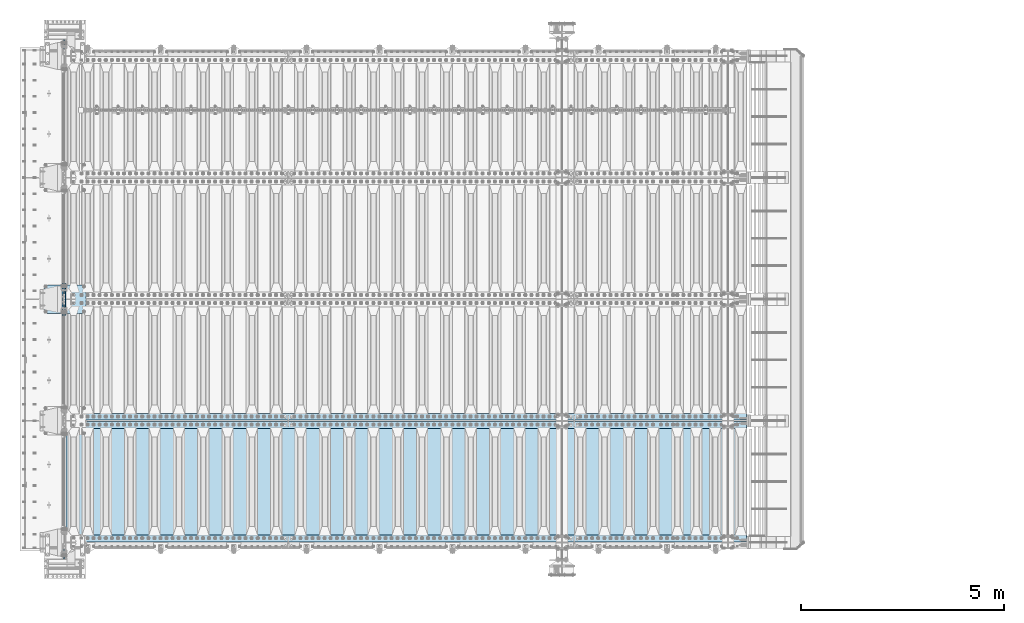
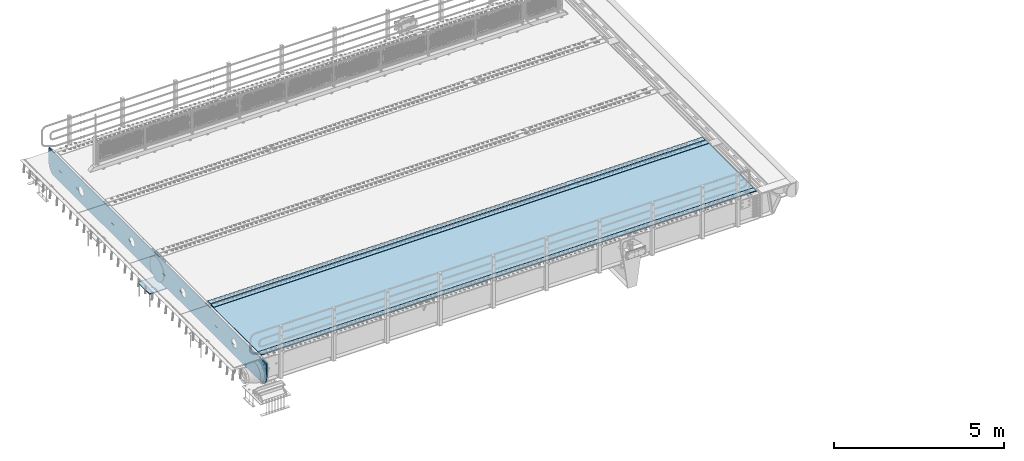
# One storey, part 197 of 257: 8 plates.
"""IFC2X3 building model written with IfcOpenShell, lengths in millimetres."""

from ifc_helpers import new_model, si_unit, frame, origin_with_axes, place, context, subcontext, project, spatial, faceted_brep, material, type_object, element, save


model = new_model("IFC2X3")

# Units and contexts
model_context = context("Model", 3, precision=1e-05, world=origin_with_axes())
body_context = subcontext(model_context, "Body", "Model", "MODEL_VIEW")
ifc_project = project(units=[si_unit("LENGTHUNIT", "METRE", prefix="MILLI"), si_unit("AREAUNIT", "SQUARE_METRE"), si_unit("VOLUMEUNIT", "CUBIC_METRE"), si_unit("MASSUNIT", "GRAM", prefix="KILO"), si_unit("TIMEUNIT", "SECOND"), si_unit("PLANEANGLEUNIT", "RADIAN"), si_unit("SOLIDANGLEUNIT", "STERADIAN"), si_unit("THERMODYNAMICTEMPERATUREUNIT", "DEGREE_CELSIUS"), si_unit("LUMINOUSINTENSITYUNIT", "LUMEN")], contexts=[model_context])

# Site, building, storey
site_placement = place(None, origin_with_axes())
site = spatial("IfcSite", under=ifc_project, at=site_placement, CompositionType="ELEMENT")
building_placement = place(site_placement, origin_with_axes())
building = spatial("IfcBuilding", under=site, at=building_placement, Name="Standard", CompositionType="ELEMENT")
storey_placement = place(building_placement, origin_with_axes())
storey = spatial("IfcBuildingStorey", under=building, at=storey_placement, Name="Undefined", CompositionType="ELEMENT", Elevation=0.0)

# Plates
ifc_material_1 = material(Name="STEEL/S355N")
plate_type_1 = type_object("IfcPlateType", PredefinedType="NOTDEFINED")
plate_1_placement = place(storey_placement, frame((42445.0, 5600.0, -20.0), z_axis=(0.0, 1.0, 0.0), x_axis=(0.0, 0.0, -1.0)))
element("IfcPlate", 1, at=plate_1_placement, inside=storey, type_object=plate_type_1, material=ifc_material_1, context=body_context, shape_type="Brep", body=[
    faceted_brep([(855.0, -15.0, 572.96311467154), (855.0, 15.0, 572.96311467154), (849.182410261294, 15.0, 585.889268817531), (849.182410261294, -15.0, 585.889268817531), (824.193546357474, 15.0, 627.225898692485), (824.193546357474, -15.0, 627.225898692485), (794.404299268454, 15.0, 665.249063296341), (794.404299268454, -15.0, 665.249063296341), (760.249063296334, 15.0, 699.404299268464), (760.249063296334, -15.0, 699.404299268464), (722.22589869248, 15.0, 729.193546357486), (722.22589869248, -15.0, 729.193546357486), (680.889268817528, 15.0, 754.182410261309), (680.889268817528, -15.0, 754.182410261309), (636.841954817037, 15.0, 774.006497074193), (636.841954817037, -15.0, 774.006497074193), (590.726265715048, 15.0, 788.37672697045), (590.726265715048, -15.0, 788.37672697045), (543.214672102156, 15.0, 797.083549639254), (543.214672102156, -15.0, 797.083549639254), (495.0, -15.0, 800.000000000029), (495.0, 15.0, 800.0), (494.999999999412, -15.0, 0.0), (494.999999999412, 15.0, 0.0), (543.214672102129, 15.0, 2.91645036080718), (543.214672102129, -15.0, 2.91645036080718), (590.726265715023, 15.0, 11.6232730296088), (590.726265715023, -15.0, 11.6232730296088), (636.841954817014, 15.0, 25.9935029258631), (636.841954817014, -15.0, 25.9935029258631), (680.889268817507, 15.0, 45.8175897387455), (680.889268817507, -15.0, 45.8175897387455), (722.225898692462, 15.0, 70.8064536425663), (722.225898692462, -15.0, 70.8064536425663), (760.249063296318, 15.0, 100.595700731588), (760.249063296318, -15.0, 100.595700731588), (794.404299268441, 15.0, 134.750936703711), (794.404299268441, -15.0, 134.750936703711), (824.193546357463, 15.0, 172.774101307567), (824.193546357463, -15.0, 172.774101307567), (849.182410261284, 15.0, 214.110731182522), (849.182410261284, -15.0, 214.110731182522), (855.0, -15.0, 227.036885328535), (855.0, 15.0, 227.036885328535), (0.0, -15.0, 0.0), (0.0, 15.0, 0.0), (0.0, 15.0, 800.0), (0.0, -15.0, 800.0)], [[[0, 1, 2, 3]], [[3, 2, 4, 5]], [[5, 4, 6, 7]], [[7, 6, 8, 9]], [[9, 8, 10, 11]], [[11, 10, 12, 13]], [[13, 12, 14, 15]], [[15, 14, 16, 17]], [[17, 16, 18, 19]], [[20, 19, 18, 21]], [[22, 23, 24, 25]], [[25, 24, 26, 27]], [[27, 26, 28, 29]], [[29, 28, 30, 31]], [[31, 30, 32, 33]], [[33, 32, 34, 35]], [[35, 34, 36, 37]], [[37, 36, 38, 39]], [[39, 38, 40, 41]], [[42, 41, 40, 43]], [[42, 43, 1, 0]], [[44, 45, 23, 22]], [[16, 14, 12, 10, 8, 6, 4, 2, 1, 43, 40, 38, 36, 34, 32, 30, 28, 26, 24, 23, 45, 46, 21, 18]], [[44, 47, 46, 45]], [[46, 47, 20, 21]], [[47, 44, 22, 25, 27, 29, 31, 33, 35, 37, 39, 41, 42, 0, 3, 5, 7, 9, 11, 13, 15, 17, 19, 20]]]),
])
plate_type_2 = type_object("IfcPlateType", PredefinedType="NOTDEFINED")
plate_2_placement = place(storey_placement, frame((41926.0, 6350.0, -1043.0), z_axis=(1.0, 0.0, 0.0), x_axis=(0.0, -1.0, 0.0)))
element("IfcPlate", 2, at=plate_2_placement, inside=storey, type_object=plate_type_2, material=ifc_material_1, context=body_context, shape_type="Brep", body=[
    faceted_brep([(0.0, -15.0, 0.0), (3.03448287013453e-05, -15.0, 1025.0), (3.03448287013453e-05, 15.0, 1025.0), (0.0, 15.0, 0.0), (700.0, -15.0, 1025.0), (700.0, 15.0, 1025.0), (700.0, -15.0, -7.27595761418343e-12), (700.0, 15.0, -7.27595761418343e-12)], [[[0, 1, 2, 3]], [[1, 4, 5, 2]], [[4, 6, 7, 5]], [[6, 0, 3, 7]], [[5, 7, 3, 2]], [[6, 4, 1, 0]]]),
])
ifc_material_2 = material(Name="STEEL/S235JR")
plate_type_3 = type_object("IfcPlateType", PredefinedType="NOTDEFINED")
for number, where, z_axis, x_axis in (
    (3, (59257.0, 2815.0, 20.0), (-1.0, 0.0, 0.0), (0.0, 1.0, 0.0)),
    (4, (59257.0, 15.0, 20.0), (-1.0, 0.0, 0.0), (0.0, 1.0, 0.0)),
    (5, (59257.0, 3015.0, 20.0), (-1.0, 0.0, 0.0), (0.0, 1.0, 0.0)),
):
    element("IfcPlate", number, at=place(storey_placement, frame(where, z_axis=z_axis, x_axis=x_axis)), inside=storey, type_object=plate_type_3, material=ifc_material_2, context=body_context, shape_type="Brep", body=[
        faceted_brep([(0.0, -6.0, 0.0), (0.0, -6.0, 16787.0), (0.0, 6.0, 16787.0), (0.0, 6.0, 0.0), (170.0, -6.0, 16787.0), (170.0, 6.0, 16787.0), (170.0, -6.0, 0.0), (170.0, 6.0, 0.0)], [[[0, 1, 2, 3]], [[1, 4, 5, 2]], [[4, 6, 7, 5]], [[6, 0, 3, 7]], [[5, 7, 3, 2]], [[6, 4, 1, 0]]]),
    ])
plate_type_4 = type_object("IfcPlateType", PredefinedType="NOTDEFINED")
plate_3_placement = place(storey_placement, frame((42460.0, 2995.0, 7.0), z_axis=(1.0, 0.0, 0.0), x_axis=(0.0, -1.0, 0.0)))
element("IfcPlate", 6, at=plate_3_placement, inside=storey, type_object=plate_type_4, material=ifc_material_1, context=body_context, shape_type="Brep", body=[
    faceted_brep([(0.0, -7.0, 0.0), (-2.96859070658684e-09, -7.0, 16807.0), (-2.96859070658684e-09, 7.0, 16807.0), (0.0, 7.0, 0.0), (2990.0, -7.0, 16807.0), (2990.0, 7.0, 16807.0), (2990.0, -7.0, 0.0), (2990.0, 7.0, 0.0)], [[[0, 1, 2, 3]], [[1, 4, 5, 2]], [[4, 6, 7, 5]], [[6, 0, 3, 7]], [[5, 7, 3, 2]], [[6, 4, 1, 0]]]),
])
plate_type_5 = type_object("IfcPlateType", PredefinedType="NOTDEFINED")
plate_4_placement = place(storey_placement, frame((42387.5, 6400.0, -114.999999999998), z_axis=(0.0, 0.0, -1.0), x_axis=(0.0, -1.0, 0.0)))
element("IfcPlate", 7, at=plate_4_placement, inside=storey, type_object=plate_type_5, material=ifc_material_1, context=body_context, shape_type="Brep", body=[
    faceted_brep([(-1.13686837721616e-13, -12.5, 400.0), (2.91645036077841, -12.5, 448.214672102129), (2.91645036077841, 12.5, 448.214672102129), (-1.13686837721616e-13, 12.5, 400.0), (11.6232730295792, -12.5, 495.726265715023), (11.6232730295792, 12.5, 495.726265715023), (25.993502925834, -12.5, 541.841954817014), (25.993502925834, 12.5, 541.841954817014), (45.817589738716, -12.5, 585.889268817507), (45.817589738716, 12.5, 585.889268817507), (70.8064536425373, -12.5, 627.225898692462), (70.8064536425373, 12.5, 627.225898692462), (100.595700731559, -12.5, 665.249063296318), (100.595700731559, 12.5, 665.249063296318), (134.750936703682, -12.5, 699.40429926844), (134.750936703682, 12.5, 699.40429926844), (172.774101307538, -12.5, 729.193546357462), (172.774101307538, 12.5, 729.193546357462), (214.110731182492, -12.5, 754.182410261284), (214.110731182492, 12.5, 754.182410261284), (258.158045182986, -12.5, 774.006497074166), (258.158045182986, 12.5, 774.006497074166), (304.273734284977, -12.5, 788.376726970421), (304.273734284977, 12.5, 788.376726970421), (351.78532789787, -12.5, 797.083549639221), (351.78532789787, 12.5, 797.083549639221), (400.0, -12.5, 800.0), (400.0, 12.5, 800.0), (448.214672102129, -12.5, 797.083549639222), (448.214672102129, 12.5, 797.083549639222), (495.726265715023, -12.5, 788.376726970421), (495.726265715023, 12.5, 788.376726970421), (541.841954817014, -12.5, 774.006497074166), (541.841954817014, 12.5, 774.006497074166), (585.889268817507, -12.5, 754.182410261284), (585.889268817507, 12.5, 754.182410261284), (627.225898692462, -12.5, 729.193546357463), (627.225898692462, 12.5, 729.193546357463), (665.249063296318, -12.5, 699.404299268441), (665.249063296318, 12.5, 699.404299268441), (699.40429926844, -12.5, 665.249063296318), (699.40429926844, 12.5, 665.249063296318), (729.193546357463, -12.5, 627.225898692462), (729.193546357463, 12.5, 627.225898692462), (754.182410261284, -12.5, 585.889268817507), (754.182410261284, 12.5, 585.889268817507), (774.006497074166, -12.5, 541.841954817014), (774.006497074166, 12.5, 541.841954817014), (788.376726970421, -12.5, 495.726265715023), (788.376726970421, 12.5, 495.726265715023), (797.083549639222, -12.5, 448.214672102129), (797.083549639222, 12.5, 448.214672102129), (800.0, -12.5, 400.0), (800.0, 12.5, 400.0), (797.083549639222, -12.5, 351.785327897871), (797.083549639222, 12.5, 351.785327897871), (788.376726970421, -12.5, 304.273734284977), (788.376726970421, 12.5, 304.273734284977), (774.006497074166, -12.5, 258.158045182986), (774.006497074166, 12.5, 258.158045182986), (754.182410261284, -12.5, 214.110731182493), (754.182410261284, 12.5, 214.110731182493), (729.193546357463, -12.5, 172.774101307538), (729.193546357463, 12.5, 172.774101307538), (699.40429926844, -12.5, 134.750936703682), (699.40429926844, 12.5, 134.750936703682), (665.249063296318, -12.5, 100.59570073156), (665.249063296318, 12.5, 100.59570073156), (627.225898692462, -12.5, 70.8064536425375), (627.225898692462, 12.5, 70.8064536425375), (585.889268817507, -12.5, 45.817589738716), (585.889268817507, 12.5, 45.817589738716), (541.841954817014, -12.5, 25.9935029258342), (541.841954817014, 12.5, 25.9935029258342), (495.726265715023, -12.5, 11.6232730295793), (495.726265715023, 12.5, 11.6232730295793), (448.214672102129, -12.5, 2.91645036077847), (448.214672102129, 12.5, 2.91645036077847), (400.0, -12.5, -5.6843418860808e-14), (400.0, 12.5, -5.6843418860808e-14), (351.785327897871, -12.5, 2.91645036077836), (351.785327897871, 12.5, 2.91645036077836), (304.273734284977, -12.5, 11.6232730295792), (304.273734284977, 12.5, 11.6232730295792), (258.158045182986, -12.5, 25.993502925834), (258.158045182986, 12.5, 25.993502925834), (214.110731182492, -12.5, 45.817589738716), (214.110731182492, 12.5, 45.817589738716), (172.774101307538, -12.5, 70.8064536425374), (172.774101307538, 12.5, 70.8064536425374), (134.750936703682, -12.5, 100.595700731559), (134.750936703682, 12.5, 100.595700731559), (100.59570073156, -12.5, 134.750936703682), (100.59570073156, 12.5, 134.750936703682), (70.8064536425373, -12.5, 172.774101307538), (70.8064536425373, 12.5, 172.774101307538), (45.817589738716, -12.5, 214.110731182492), (45.817589738716, 12.5, 214.110731182492), (25.993502925834, -12.5, 258.158045182986), (25.993502925834, 12.5, 258.158045182986), (11.6232730295791, -12.5, 304.273734284977), (11.6232730295791, 12.5, 304.273734284977), (2.91645036077836, -12.5, 351.785327897871), (2.91645036077836, 12.5, 351.785327897871)], [[[0, 1, 2, 3]], [[1, 4, 5, 2]], [[4, 6, 7, 5]], [[6, 8, 9, 7]], [[8, 10, 11, 9]], [[10, 12, 13, 11]], [[12, 14, 15, 13]], [[14, 16, 17, 15]], [[16, 18, 19, 17]], [[18, 20, 21, 19]], [[20, 22, 23, 21]], [[22, 24, 25, 23]], [[24, 26, 27, 25]], [[26, 28, 29, 27]], [[28, 30, 31, 29]], [[30, 32, 33, 31]], [[32, 34, 35, 33]], [[34, 36, 37, 35]], [[36, 38, 39, 37]], [[38, 40, 41, 39]], [[40, 42, 43, 41]], [[42, 44, 45, 43]], [[44, 46, 47, 45]], [[46, 48, 49, 47]], [[48, 50, 51, 49]], [[50, 52, 53, 51]], [[52, 54, 55, 53]], [[54, 56, 57, 55]], [[56, 58, 59, 57]], [[58, 60, 61, 59]], [[60, 62, 63, 61]], [[62, 64, 65, 63]], [[64, 66, 67, 65]], [[66, 68, 69, 67]], [[68, 70, 71, 69]], [[70, 72, 73, 71]], [[72, 74, 75, 73]], [[74, 76, 77, 75]], [[76, 78, 79, 77]], [[78, 80, 81, 79]], [[80, 82, 83, 81]], [[82, 84, 85, 83]], [[84, 86, 87, 85]], [[86, 88, 89, 87]], [[88, 90, 91, 89]], [[90, 92, 93, 91]], [[92, 94, 95, 93]], [[94, 96, 97, 95]], [[96, 98, 99, 97]], [[98, 100, 101, 99]], [[100, 102, 103, 101]], [[102, 0, 3, 103]], [[5, 7, 9, 11, 13, 15, 17, 19, 21, 23, 25, 27, 29, 31, 33, 35, 37, 39, 41, 43, 45, 47, 49, 51, 53, 55, 57, 59, 61, 63, 65, 67, 69, 71, 73, 75, 77, 79, 81, 83, 85, 87, 89, 91, 93, 95, 97, 99, 101, 103, 3, 2]], [[102, 100, 98, 96, 94, 92, 90, 88, 86, 84, 82, 80, 78, 76, 74, 72, 70, 68, 66, 64, 62, 60, 58, 56, 54, 52, 50, 48, 46, 44, 42, 40, 38, 36, 34, 32, 30, 28, 26, 24, 22, 20, 18, 16, 14, 12, 10, 8, 6, 4, 1, 0]]]),
])
plate_type_6 = type_object("IfcPlateType", PredefinedType="NOTDEFINED")
plate_5_placement = place(storey_placement, frame((42415.0, -400.0, -36.0000190935184), z_axis=(0.0, 1.0, 0.0), x_axis=(0.0, 0.0, -1.0)))
element("IfcPlate", 8, at=plate_5_placement, inside=storey, type_object=plate_type_6, material=ifc_material_1, context=body_context, shape_type="Brep", body=[
    faceted_brep([(449.26354918649, -15.0, 2047.11778936597), (449.26354918649, 15.0, 2047.11778936597), (477.402515687619, 15.0, 2038.58192701334), (477.402515687619, -15.0, 2038.58192701334), (503.335535702627, 15.0, 2024.72043882643), (503.335535702627, -15.0, 2024.72043882643), (526.066017815742, 15.0, 2006.06601402265), (526.066017815742, -15.0, 2006.06601402265), (544.720442346759, 15.0, 1983.33553168568), (544.720442346759, -15.0, 1983.33553168568), (558.581930222472, 15.0, 1957.40251150434), (558.581930222472, -15.0, 1957.40251150434), (567.11779223743, 15.0, 1929.26354490078), (567.11779223743, -15.0, 1929.26354490078), (570.000000001364, 15.0, 1899.99999658107), (570.000000001364, -15.0, 1899.99999658107), (567.117791886267, 15.0, 1870.73644829594), (567.117791886267, -15.0, 1870.73644829594), (558.581929533642, 15.0, 1842.59748179481), (558.581929533642, -15.0, 1842.59748179481), (544.720441346732, 15.0, 1816.6644617798), (544.720441346732, -15.0, 1816.6644617798), (526.06601654295, 15.0, 1793.93397966669), (526.06601654295, -15.0, 1793.93397966669), (503.335534205981, 15.0, 1775.27955513567), (503.335534205981, -15.0, 1775.27955513567), (477.402514024636, 15.0, 1761.41806725996), (477.402514024636, -15.0, 1761.41806725996), (449.263547421076, 15.0, 1752.882205245), (449.263547421076, -15.0, 1752.882205245), (419.999999101364, 15.0, 1749.99999748107), (419.999999101364, -15.0, 1749.99999748107), (390.736450816238, 15.0, 1752.88220559616), (390.736450816238, -15.0, 1752.88220559616), (362.597484315109, 15.0, 1761.41806794879), (362.597484315109, -15.0, 1761.41806794879), (336.664464300101, 15.0, 1775.2795561357), (336.664464300101, -15.0, 1775.2795561357), (313.933982186985, 15.0, 1793.93398093948), (313.933982186985, -15.0, 1793.93398093948), (295.279557655969, 15.0, 1816.66446327645), (295.279557655969, -15.0, 1816.66446327645), (281.418069780255, 15.0, 1842.59748345779), (281.418069780255, -15.0, 1842.59748345779), (272.882207765298, 15.0, 1870.73645006135), (272.882207765298, -15.0, 1870.73645006135), (270.000000001364, 15.0, 1899.99999838107), (270.000000001364, -15.0, 1899.99999838107), (272.88220811646, 15.0, 1929.26354666619), (272.88220811646, -15.0, 1929.26354666619), (281.418070469086, 15.0, 1957.40251316732), (281.418070469086, -15.0, 1957.40251316732), (295.279558655995, 15.0, 1983.33553318233), (295.279558655995, -15.0, 1983.33553318233), (313.933983459778, 15.0, 2006.06601529544), (313.933983459778, -15.0, 2006.06601529544), (336.664465796746, 15.0, 2024.72043982646), (336.664465796746, -15.0, 2024.72043982646), (362.597485978092, 15.0, 2038.58192770217), (362.597485978092, -15.0, 2038.58192770217), (390.736452581651, 15.0, 2047.11778971713), (390.736452581651, -15.0, 2047.11778971713), (420.000000901364, 15.0, 2049.99999748107), (420.000000901364, -15.0, 2049.99999748107), (-8.67287788253179e-07, 15.0, 12800.0), (-8.67287788253179e-07, -15.0, 12800.0), (479.000057696533, -15.0, 12799.9999971272), (479.000057666522, 15.0, 12800.0), (0.0, -15.0, 0.0), (0.0, 15.0, 0.0), (479.000000000273, 15.0, -1.02318153949454e-12), (479.000000000273, -15.0, -1.02318153949454e-12), (527.214672102249, 15.0, 2.91645036083003), (527.214672102249, -15.0000000000073, 2.91645036083003), (574.726265715176, 15.0, 11.6232730296886), (574.726265715176, -15.0000000000073, 11.6232730296886), (620.8419548172, 15.0, 25.993502925999), (620.8419548172, -15.0000000000073, 25.993502925999), (664.889268817721, 15.0, 45.8175897389338), (664.889268817721, -15.0000000000073, 45.8175897389338), (706.225898692704, 15.0, 70.806453642805), (706.225898692704, -15.0000000000073, 70.806453642805), (744.249063296587, 15.0, 100.595700731874), (744.249063296587, -15.0000000000073, 100.595700731874), (778.404299268733, 15.0, 134.75093670404), (778.404299268733, -15.0000000000073, 134.75093670404), (808.193546357779, 15.0, 172.774101307936), (808.193546357779, -15.0000000000073, 172.774101307936), (833.182410261624, 15.0, 214.110731182928), (833.182410261624, -15.0000000000073, 214.110731182928), (838.999998917404, -15.0, 227.036882922753), (838.999998917404, 15.0, 227.036882922751), (838.999940047439, 15.0, 12572.9632668301), (838.999940047439, -15.0, 12572.9632668968), (833.182425775347, 15.0, 12585.8892544662), (833.182425805347, -14.9999999999927, 12585.8892544662), (808.193562544399, 15.0, 12627.225886117), (808.193562574399, -14.9999999999927, 12627.225886117), (778.4043157977, 15.0, 12665.2490524775), (778.4043158277, -14.9999999999927, 12665.2490524775), (744.249079853432, 15.0, 12699.4042901345), (744.249079883432, -14.9999999999927, 12699.4042901345), (706.225914986719, 15.0, 12729.1935387878), (706.225915016719, -14.9999999999927, 12729.1935387878), (664.889284588931, 15.0, 12754.1824040915), (664.889284618931, -14.9999999999927, 12754.1824040915), (620.841969842492, 15.0, 12774.0064921019), (620.841969872492, -14.9999999999927, 12774.0064921019), (574.726279813484, 15.0, 12788.3767229616), (574.726279843484, -14.9999999999927, 12788.3767229616), (527.214685138648, 15.0, 12797.0835463356), (527.214685168648, -14.9999999999927, 12797.0835463356), (390.736498881952, -15.0, 11047.1177897171), (390.736498881952, 15.0, 11047.1177897171), (420.000047201664, 15.0, 11049.9999974811), (420.000047201664, -15.0, 11049.9999974811), (362.597532278392, -15.0, 11038.5819277022), (362.597532278392, 15.0, 11038.5819277022), (336.664512097047, -15.0, 11024.7204398265), (336.664512097047, 15.0, 11024.7204398265), (313.934029760078, -15.0, 11006.0660152954), (313.934029760078, 15.0, 11006.0660152954), (295.279604956296, -15.0, 10983.3355331823), (295.279604956296, 15.0, 10983.3355331823), (281.418116769386, -15.0, 10957.4025131673), (281.418116769386, 15.0, 10957.4025131673), (272.882254416761, -15.0, 10929.2635466662), (272.882254416761, 15.0, 10929.2635466662), (270.000046301664, -15.0, 10899.9999983811), (270.000046301664, 15.0, 10899.9999983811), (272.882254065598, -15.0, 10870.7364500614), (272.882254065598, 15.0, 10870.7364500614), (281.418116080556, -15.0, 10842.5974834578), (281.418116080556, 15.0, 10842.5974834578), (295.279603956269, -15.0, 10816.6644632764), (295.279603956269, 15.0, 10816.6644632764), (313.934028487286, -15.0, 10793.9339809395), (313.934028487286, 15.0, 10793.9339809395), (336.664510600401, -15.0, 10775.2795561357), (336.664510600401, 15.0, 10775.2795561357), (362.597530615409, -15.0, 10761.4180679488), (362.597530615409, 15.0, 10761.4180679488), (390.736497116538, -15.0, 10752.8822055962), (390.736497116538, 15.0, 10752.8822055962), (420.000045401664, -15.0, 10749.9999974811), (420.000045401664, 15.0, 10749.9999974811), (449.263593721377, -15.0, 10752.882205245), (449.263593721377, 15.0, 10752.882205245), (477.402560324936, -15.0, 10761.41806726), (477.402560324936, 15.0, 10761.41806726), (503.335580506282, -15.0, 10775.2795551357), (503.335580506282, 15.0, 10775.2795551357), (526.06606284325, -15.0, 10793.9339796667), (526.06606284325, 15.0, 10793.9339796667), (544.720487647033, -15.0, 10816.6644617798), (544.720487647033, 15.0, 10816.6644617798), (558.581975833942, -15.0, 10842.5974817948), (558.581975833942, 15.0, 10842.5974817948), (567.117838186568, -15.0, 10870.7364482959), (567.117838186568, 15.0, 10870.7364482959), (570.000046301664, -15.0, 10899.9999965811), (570.000046301664, 15.0, 10899.9999965811), (567.11783853773, -15.0, 10929.2635449008), (567.11783853773, 15.0, 10929.2635449008), (558.581976522772, -15.0, 10957.4025115043), (558.581976522772, 15.0, 10957.4025115043), (544.720488647059, -15.0, 10983.3355316857), (544.720488647059, 15.0, 10983.3355316857), (526.066064116043, -15.0, 11006.0660140227), (526.066064116043, 15.0, 11006.0660140227), (503.335582002927, -15.0, 11024.7204388264), (503.335582002927, 15.0, 11024.7204388264), (477.402561987919, -15.0, 11038.5819270133), (477.402561987919, 15.0, 11038.5819270133), (449.26359548679, -15.0, 11047.117789366), (449.26359548679, 15.0, 11047.117789366), (390.736483441909, -15.0, 8047.11778971713), (390.736483441909, 15.0, 8047.11778971713), (420.000031761622, 15.0, 8049.99999748107), (420.000031761622, -15.0, 8049.99999748107), (362.59751683835, -15.0, 8038.58192770217), (362.59751683835, 15.0, 8038.58192770217), (336.664496657004, -15.0, 8024.72043982646), (336.664496657004, 15.0, 8024.72043982646), (313.934014320036, -15.0, 8006.06601529544), (313.934014320036, 15.0, 8006.06601529544), (295.279589516253, -15.0, 7983.33553318233), (295.279589516253, 15.0, 7983.33553318233), (281.418101329344, -15.0, 7957.40251316732), (281.418101329344, 15.0, 7957.40251316732), (272.882238976718, -15.0, 7929.26354666619), (272.882238976718, 15.0, 7929.26354666619), (270.000030861622, -15.0, 7899.99999838107), (270.000030861622, 15.0, 7899.99999838107), (272.882238625556, -15.0, 7870.73645006135), (272.882238625556, 15.0, 7870.73645006135), (281.418100640514, -15.0, 7842.59748345779), (281.418100640514, 15.0, 7842.59748345779), (295.279588516227, -15.0, 7816.66446327645), (295.279588516227, 15.0, 7816.66446327645), (313.934013047243, -15.0, 7793.93398093948), (313.934013047243, 15.0, 7793.93398093948), (336.664495160359, -15.0, 7775.2795561357), (336.664495160359, 15.0, 7775.2795561357), (362.597515175367, -15.0, 7761.41806794879), (362.597515175367, 15.0, 7761.41806794879), (390.736481676496, -15.0, 7752.88220559616), (390.736481676496, 15.0, 7752.88220559616), (420.000029961622, -15.0, 7749.99999748107), (420.000029961622, 15.0, 7749.99999748107), (449.263578281334, -15.0, 7752.882205245), (449.263578281334, 15.0, 7752.882205245), (477.402544884894, -15.0, 7761.41806725996), (477.402544884894, 15.0, 7761.41806725996), (503.335565066239, -15.0, 7775.27955513567), (503.335565066239, 15.0, 7775.27955513567), (526.066047403208, -15.0, 7793.93397966669), (526.066047403208, 15.0, 7793.93397966669), (544.72047220699, -15.0, 7816.6644617798), (544.72047220699, 15.0, 7816.6644617798), (558.5819603939, -15.0, 7842.59748179481), (558.5819603939, 15.0, 7842.59748179481), (567.117822746525, -15.0, 7870.73644829594), (567.117822746525, 15.0, 7870.73644829594), (570.000030861622, -15.0, 7899.99999658107), (570.000030861622, 15.0, 7899.99999658107), (567.117823097687, -15.0, 7929.26354490078), (567.117823097687, 15.0, 7929.26354490078), (558.58196108273, -15.0, 7957.40251150434), (558.58196108273, 15.0, 7957.40251150434), (544.720473207017, -15.0, 7983.33553168568), (544.720473207017, 15.0, 7983.33553168568), (526.066048676, -15.0, 8006.06601402265), (526.066048676, 15.0, 8006.06601402265), (503.335566562885, -15.0, 8024.72043882643), (503.335566562885, 15.0, 8024.72043882643), (477.402546547877, -15.0, 8038.58192701334), (477.402546547877, 15.0, 8038.58192701334), (449.263580046748, -15.0, 8047.11778936597), (449.263580046748, 15.0, 8047.11778936597), (477.402531121052, -15.0, 5038.58192701334), (503.33555113606, -15.0, 5024.72043882643), (526.066033249175, -15.0, 5006.06601402265), (544.720457780192, -15.0, 4983.33553168568), (558.581945655905, -15.0, 4957.40251150434), (567.117807670863, -15.0, 4929.26354490078), (570.000015434797, -15.0, 4899.99999658107), (567.1178073197, -15.0, 4870.73644829594), (558.581944967075, -15.0, 4842.59748179481), (544.720456780166, -15.0, 4816.6644617798), (526.066031976383, -15.0, 4793.93397966669), (503.335549639415, -15.0, 4775.27955513567), (477.402529458069, -15.0, 4761.41806725996), (449.26356285451, -15.0, 4752.882205245), (420.000014534797, -15.0, 4749.99999748107), (390.736466249671, -15.0, 4752.88220559616), (362.597499748542, -15.0, 4761.41806794879), (336.664479733534, -15.0, 4775.2795561357), (313.933997620419, -15.0, 4793.93398093948), (295.279573089402, -15.0, 4816.66446327645), (281.418085213689, -15.0, 4842.59748345779), (272.882223198731, -15.0, 4870.73645006135), (270.000015434797, -15.0, 4899.99999838107), (272.882223549894, -15.0, 4929.26354666619), (281.418085902519, -15.0, 4957.40251316732), (295.279574089429, -15.0, 4983.33553318233), (313.933998893211, -15.0, 5006.06601529544), (336.664481230179, -15.0, 5024.72043982646), (362.597501411525, -15.0, 5038.58192770217), (390.736468015085, -15.0, 5047.11778971713), (420.000016334797, -15.0, 5049.99999748107), (449.263564619923, -15.0, 5047.11778936597), (362.597501411525, 15.0, 5038.58192770217), (390.736468015085, 15.0, 5047.11778971713), (336.664481230179, 15.0, 5024.72043982646), (313.933998893211, 15.0, 5006.06601529544), (295.279574089429, 15.0, 4983.33553318233), (281.418085902519, 15.0, 4957.40251316732), (272.882223549894, 15.0, 4929.26354666619), (270.000015434797, 15.0, 4899.99999838107), (272.882223198731, 15.0, 4870.73645006135), (281.418085213689, 15.0, 4842.59748345779), (295.279573089402, 15.0, 4816.66446327645), (313.933997620419, 15.0, 4793.93398093948), (336.664479733534, 15.0, 4775.2795561357), (362.597499748542, 15.0, 4761.41806794879), (390.736466249671, 15.0, 4752.88220559616), (420.000014534797, 15.0, 4749.99999748107), (449.26356285451, 15.0, 4752.882205245), (477.402529458069, 15.0, 4761.41806725996), (503.335549639415, 15.0, 4775.27955513567), (526.066031976383, 15.0, 4793.93397966669), (544.720456780166, 15.0, 4816.6644617798), (558.581944967075, 15.0, 4842.59748179481), (567.1178073197, 15.0, 4870.73644829594), (570.000015434797, 15.0, 4899.99999658107), (567.117807670863, 15.0, 4929.26354490078), (558.581945655905, 15.0, 4957.40251150434), (544.720457780192, 15.0, 4983.33553168568), (526.066033249175, 15.0, 5006.06601402265), (503.33555113606, 15.0, 5024.72043882643), (477.402531121052, 15.0, 5038.58192701334), (449.263564619923, 15.0, 5047.11778936597), (420.000016334797, 15.0, 5049.99999748107)], [[[0, 1, 2, 3]], [[3, 2, 4, 5]], [[5, 4, 6, 7]], [[7, 6, 8, 9]], [[9, 8, 10, 11]], [[11, 10, 12, 13]], [[13, 12, 14, 15]], [[15, 14, 16, 17]], [[17, 16, 18, 19]], [[19, 18, 20, 21]], [[21, 20, 22, 23]], [[23, 22, 24, 25]], [[25, 24, 26, 27]], [[27, 26, 28, 29]], [[29, 28, 30, 31]], [[31, 30, 32, 33]], [[33, 32, 34, 35]], [[35, 34, 36, 37]], [[37, 36, 38, 39]], [[39, 38, 40, 41]], [[41, 40, 42, 43]], [[43, 42, 44, 45]], [[45, 44, 46, 47]], [[47, 46, 48, 49]], [[49, 48, 50, 51]], [[51, 50, 52, 53]], [[53, 52, 54, 55]], [[55, 54, 56, 57]], [[57, 56, 58, 59]], [[59, 58, 60, 61]], [[61, 60, 62, 63]], [[63, 62, 1, 0]], [[64, 65, 66, 67]], [[68, 65, 64, 69]], [[68, 69, 70, 71]], [[71, 70, 72, 73]], [[73, 72, 74, 75]], [[75, 74, 76, 77]], [[77, 76, 78, 79]], [[79, 78, 80, 81]], [[81, 80, 82, 83]], [[83, 82, 84, 85]], [[85, 84, 86, 87]], [[87, 86, 88, 89]], [[90, 89, 88, 91]], [[90, 91, 92, 93]], [[93, 92, 94, 95]], [[95, 94, 96, 97]], [[97, 96, 98, 99]], [[99, 98, 100, 101]], [[101, 100, 102, 103]], [[103, 102, 104, 105]], [[105, 104, 106, 107]], [[107, 106, 108, 109]], [[109, 108, 110, 111]], [[66, 111, 110, 67]], [[112, 113, 114, 115]], [[116, 117, 113, 112]], [[118, 119, 117, 116]], [[120, 121, 119, 118]], [[122, 123, 121, 120]], [[124, 125, 123, 122]], [[126, 127, 125, 124]], [[128, 129, 127, 126]], [[130, 131, 129, 128]], [[132, 133, 131, 130]], [[134, 135, 133, 132]], [[136, 137, 135, 134]], [[138, 139, 137, 136]], [[140, 141, 139, 138]], [[142, 143, 141, 140]], [[144, 145, 143, 142]], [[146, 147, 145, 144]], [[148, 149, 147, 146]], [[150, 151, 149, 148]], [[152, 153, 151, 150]], [[154, 155, 153, 152]], [[156, 157, 155, 154]], [[158, 159, 157, 156]], [[160, 161, 159, 158]], [[162, 163, 161, 160]], [[164, 165, 163, 162]], [[166, 167, 165, 164]], [[168, 169, 167, 166]], [[170, 171, 169, 168]], [[172, 173, 171, 170]], [[174, 175, 173, 172]], [[115, 114, 175, 174]], [[176, 177, 178, 179]], [[180, 181, 177, 176]], [[182, 183, 181, 180]], [[184, 185, 183, 182]], [[186, 187, 185, 184]], [[188, 189, 187, 186]], [[190, 191, 189, 188]], [[192, 193, 191, 190]], [[194, 195, 193, 192]], [[196, 197, 195, 194]], [[198, 199, 197, 196]], [[200, 201, 199, 198]], [[202, 203, 201, 200]], [[204, 205, 203, 202]], [[206, 207, 205, 204]], [[208, 209, 207, 206]], [[210, 211, 209, 208]], [[212, 213, 211, 210]], [[214, 215, 213, 212]], [[216, 217, 215, 214]], [[218, 219, 217, 216]], [[220, 221, 219, 218]], [[222, 223, 221, 220]], [[224, 225, 223, 222]], [[226, 227, 225, 224]], [[228, 229, 227, 226]], [[230, 231, 229, 228]], [[232, 233, 231, 230]], [[234, 235, 233, 232]], [[236, 237, 235, 234]], [[238, 239, 237, 236]], [[179, 178, 239, 238]], [[65, 68, 71, 73, 75, 77, 79, 81, 83, 85, 87, 89, 90, 93, 95, 97, 99, 101, 103, 105, 107, 109, 111, 66], [3, 5, 7, 9, 11, 13, 15, 17, 19, 21, 23, 25, 27, 29, 31, 33, 35, 37, 39, 41, 43, 45, 47, 49, 51, 53, 55, 57, 59, 61, 63, 0], [240, 241, 242, 243, 244, 245, 246, 247, 248, 249, 250, 251, 252, 253, 254, 255, 256, 257, 258, 259, 260, 261, 262, 263, 264, 265, 266, 267, 268, 269, 270, 271], [236, 234, 232, 230, 228, 226, 224, 222, 220, 218, 216, 214, 212, 210, 208, 206, 204, 202, 200, 198, 196, 194, 192, 190, 188, 186, 184, 182, 180, 176, 179, 238], [172, 170, 168, 166, 164, 162, 160, 158, 156, 154, 152, 150, 148, 146, 144, 142, 140, 138, 136, 134, 132, 130, 128, 126, 124, 122, 120, 118, 116, 112, 115, 174]], [[268, 272, 273, 269]], [[267, 274, 272, 268]], [[266, 275, 274, 267]], [[265, 276, 275, 266]], [[264, 277, 276, 265]], [[263, 278, 277, 264]], [[262, 279, 278, 263]], [[261, 280, 279, 262]], [[260, 281, 280, 261]], [[259, 282, 281, 260]], [[258, 283, 282, 259]], [[257, 284, 283, 258]], [[256, 285, 284, 257]], [[255, 286, 285, 256]], [[254, 287, 286, 255]], [[253, 288, 287, 254]], [[252, 289, 288, 253]], [[251, 290, 289, 252]], [[250, 291, 290, 251]], [[249, 292, 291, 250]], [[248, 293, 292, 249]], [[247, 294, 293, 248]], [[246, 295, 294, 247]], [[245, 296, 295, 246]], [[244, 297, 296, 245]], [[243, 298, 297, 244]], [[242, 299, 298, 243]], [[241, 300, 299, 242]], [[240, 301, 300, 241]], [[271, 302, 301, 240]], [[270, 303, 302, 271]], [[269, 273, 303, 270]], [[108, 106, 104, 102, 100, 98, 96, 94, 92, 91, 88, 86, 84, 82, 80, 78, 76, 74, 72, 70, 69, 64, 67, 110], [58, 56, 54, 52, 50, 48, 46, 44, 42, 40, 38, 36, 34, 32, 30, 28, 26, 24, 22, 20, 18, 16, 14, 12, 10, 8, 6, 4, 2, 1, 62, 60], [272, 274, 275, 276, 277, 278, 279, 280, 281, 282, 283, 284, 285, 286, 287, 288, 289, 290, 291, 292, 293, 294, 295, 296, 297, 298, 299, 300, 301, 302, 303, 273], [181, 183, 185, 187, 189, 191, 193, 195, 197, 199, 201, 203, 205, 207, 209, 211, 213, 215, 217, 219, 221, 223, 225, 227, 229, 231, 233, 235, 237, 239, 178, 177], [117, 119, 121, 123, 125, 127, 129, 131, 133, 135, 137, 139, 141, 143, 145, 147, 149, 151, 153, 155, 157, 159, 161, 163, 165, 167, 169, 171, 173, 175, 114, 113]]]),
])

save(model, "model.ifc")
